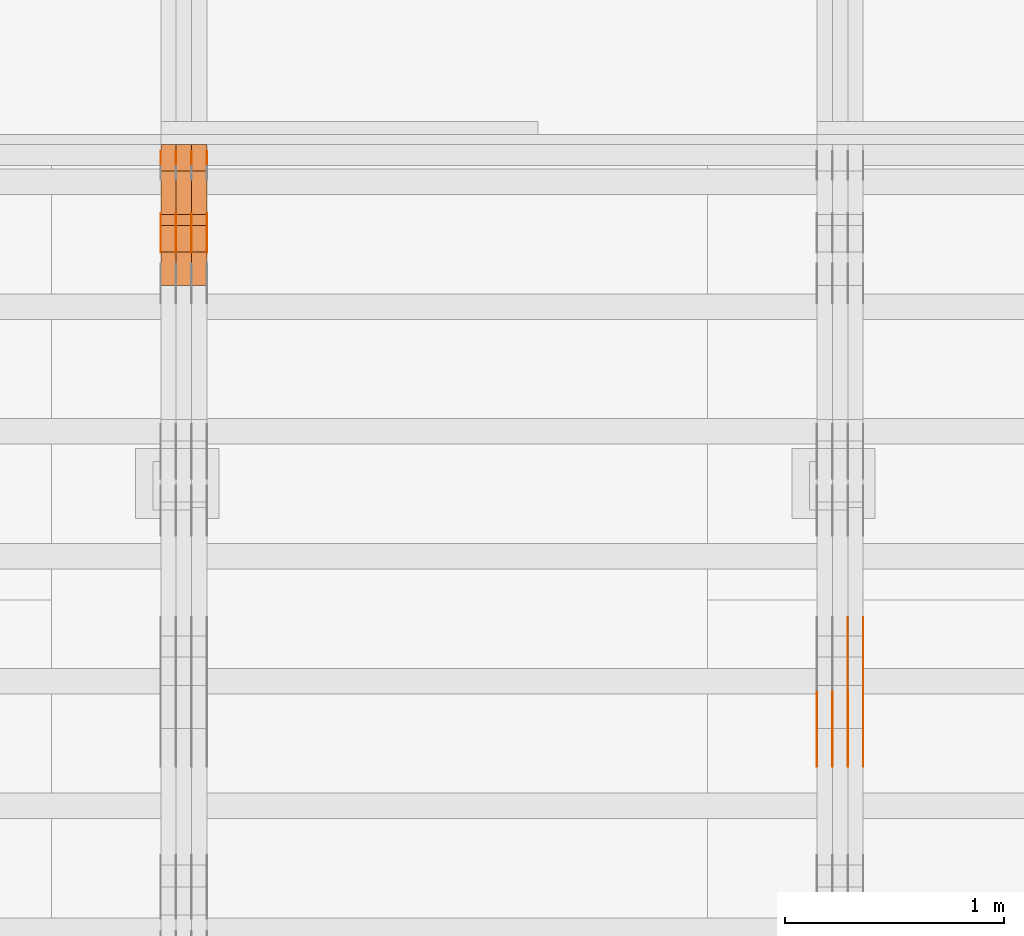
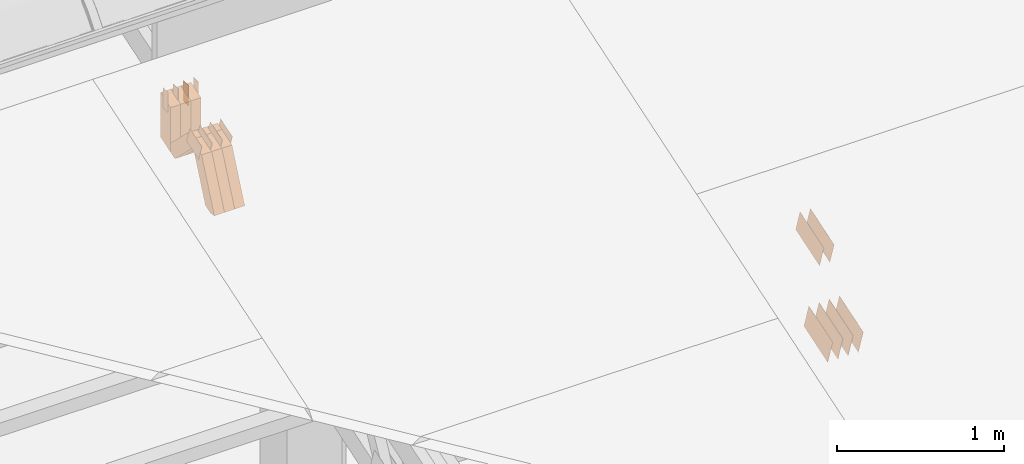
# One storey, part 279 of 385: 29 proxies.
"""IFC2X3 building model written with IfcOpenShell, lengths in millimetres."""

import ifcopenshell
import ifcopenshell.guid

model = None  # the IFC model being written
_history = None  # IfcOwnerHistory: only IFC2X3 demands one
_inside = {}  # id of a spatial element -> (the spatial element, [elements in it])
_under = {}  # id of a project, library or spatial element -> (it, [spatial elements below it])
_declared = {}  # id of a project -> (the project, [libraries it declares])
_typed = {}  # id of a type object -> (the type object, [elements of that type])
_made_of = {}  # id of a material, layer set ... -> (it, [elements and type objects made of it])


def new_model(schema):
    """Start an empty IFC model of exactly this schema.

    Asked for "IFC4X3", IfcOpenShell would pick the latest addendum, in which some entities
    have other attributes; the version numbers below select the first issue.
    IFC2X3 requires an IfcOwnerHistory on every rooted entity: one is made here for all.
    """
    global model, _history
    if schema == "IFC4X3":
        model = ifcopenshell.file(schema_version=(4, 3, 0, 0))
    else:
        model = ifcopenshell.file(schema=schema)
    _inside.clear()
    _under.clear()
    _declared.clear()
    _typed.clear()
    _made_of.clear()
    _history = None
    if model.schema == "IFC2X3":
        org = make("IfcOrganization", Name="unknown")
        user = make(
            "IfcPersonAndOrganization",
            ThePerson=make("IfcPerson", FamilyName="unknown"),
            TheOrganization=org,
        )
        app = make(
            "IfcApplication",
            ApplicationDeveloper=org,
            Version="unknown",
            ApplicationFullName="unknown",
            ApplicationIdentifier="unknown",
        )
        _history = make(
            "IfcOwnerHistory",
            OwningUser=user,
            OwningApplication=app,
            ChangeAction="ADDED",
            CreationDate=0,
        )
    return model


def make(cls, **values):
    """One entity of the class cls with the attributes given. An attribute that is None is left unset."""
    return model.create_entity(
        cls, **{name: value for name, value in values.items() if value is not None}
    )


def entity(cls, *values):
    """Any entity or typed value of the class cls, its attributes in the order of the schema. None: left unset."""
    e = model.create_entity(cls)
    for i, value in enumerate(values):
        if value is not None:
            e[i] = value
    return e


def rooted(cls, **values):
    """An entity with a GlobalId (a new one), such as an element, a storey or a relation."""
    return make(cls, GlobalId=ifcopenshell.guid.new(), OwnerHistory=_history, **values)


def si_unit(unit_type, name, prefix=None):
    """IfcSIUnit, for example si_unit("LENGTHUNIT", "METRE", prefix="MILLI")."""
    return make("IfcSIUnit", UnitType=unit_type, Prefix=prefix, Name=name)


def converted_unit(unit_type, name, factor, base, dimensions=None, offset=None):
    """IfcConversionBasedUnit, such as the inch: factor (a typed value) times the base unit."""
    return make(
        "IfcConversionBasedUnit"
        if offset is None
        else "IfcConversionBasedUnitWithOffset",
        ConversionOffset=offset,
        Dimensions=None
        if dimensions is None
        else entity("IfcDimensionalExponents", *dimensions),
        UnitType=unit_type,
        Name=name,
        ConversionFactor=make(
            "IfcMeasureWithUnit", ValueComponent=factor, UnitComponent=base
        ),
    )


def derived_unit(unit_type, elements):
    """IfcDerivedUnit: a product of units, each with its exponent."""
    return make(
        "IfcDerivedUnit",
        Elements=[
            make("IfcDerivedUnitElement", Unit=unit, Exponent=power)
            for unit, power in elements
        ],
        UnitType=unit_type,
    )


def assignment(units):
    """IfcUnitAssignment: the units of a project."""
    return None if units is None else make("IfcUnitAssignment", Units=units)


def point(xyz):
    """IfcCartesianPoint."""
    return None if xyz is None else make("IfcCartesianPoint", Coordinates=xyz)


def direction(xyz):
    """IfcDirection."""
    return None if xyz is None else make("IfcDirection", DirectionRatios=xyz)


def frame(location, z_axis=None, x_axis=None):
    """IfcAxis2Placement3D, a coordinate frame: its origin and axes. An axis left out is left unset."""
    return make(
        "IfcAxis2Placement3D",
        Location=point(location),
        Axis=direction(z_axis),
        RefDirection=direction(x_axis),
    )


def frame_2d(location, x_axis=None):
    """IfcAxis2Placement2D, a coordinate frame in the plane: its origin and x axis."""
    return make(
        "IfcAxis2Placement2D", Location=point(location), RefDirection=direction(x_axis)
    )


def origin():
    """The frame at (0, 0, 0) with its axes left unset."""
    return frame((0.0, 0.0, 0.0))


def origin_2d_with_axis():
    """The frame at (0, 0) in the plane with the x axis (1, 0) written out."""
    return frame_2d((0.0, 0.0), x_axis=(1.0, 0.0))


def place(relative_to, where):
    """IfcLocalPlacement: puts the frame where relative to a parent placement (None: the world)."""
    return make(
        "IfcLocalPlacement", PlacementRelTo=relative_to, RelativePlacement=where
    )


def context(
    kind, dimensions, precision=None, world=None, true_north=None, identifier=None
):
    """IfcGeometricRepresentationContext, for example the 3D "Model" context."""
    return make(
        "IfcGeometricRepresentationContext",
        ContextIdentifier=identifier,
        ContextType=kind,
        CoordinateSpaceDimension=dimensions,
        Precision=precision,
        WorldCoordinateSystem=world,
        TrueNorth=true_north,
    )


def subcontext(parent, identifier, kind, view, scale=None):
    """IfcGeometricRepresentationSubContext, for example "Body" below "Model"."""
    return make(
        "IfcGeometricRepresentationSubContext",
        ContextIdentifier=identifier,
        ContextType=kind,
        ParentContext=parent,
        TargetScale=scale,
        TargetView=view,
    )


def project(units=None, contexts=None):
    """IfcProject with its units and contexts."""
    return rooted(
        "IfcProject",
        Name="project",
        RepresentationContexts=contexts,
        UnitsInContext=assignment(units),
    )


def spatial(cls, under=None, at=None, **own):
    """A site, building, storey or space (cls), placed at a placement, below another one or the project."""
    s = rooted(cls, ObjectPlacement=at, **own)
    if under is not None:
        _under.setdefault(under.id(), (under, []))[1].append(s)
    return s


def polyline(points):
    """IfcPolyline through the points."""
    return make("IfcPolyline", Points=[point(p) for p in points])


def profile(cls, at=None, kind="AREA", **sizes):
    """A parametric profile (cls). Its sizes go by their IFC names, for example OverallWidth=200.0."""
    return make(cls, ProfileType=kind, Position=at, **sizes)


def rectangle(**sizes):
    """IfcRectangleProfileDef."""
    return profile("IfcRectangleProfileDef", **sizes)


def outline(outer, holes=None, kind="AREA"):
    """IfcArbitraryClosedProfileDef: a profile drawn as a closed curve; with holes, ...WithVoids."""
    if holes is None:
        return make("IfcArbitraryClosedProfileDef", ProfileType=kind, OuterCurve=outer)
    return make(
        "IfcArbitraryProfileDefWithVoids",
        ProfileType=kind,
        OuterCurve=outer,
        InnerCurves=holes,
    )


def extrude(swept, where, along, depth):
    """IfcExtrudedAreaSolid: the profile swept, set in the frame where, extruded along a direction by depth."""
    return make(
        "IfcExtrudedAreaSolid",
        SweptArea=swept,
        Position=where,
        ExtrudedDirection=direction(along),
        Depth=depth,
    )


def shape(context_of_items, identifier, shape_type, items):
    """IfcShapeRepresentation: the items that make up one representation, for example the "Body"."""
    return make(
        "IfcShapeRepresentation",
        ContextOfItems=context_of_items,
        RepresentationIdentifier=identifier,
        RepresentationType=shape_type,
        Items=items,
    )


def source(mapping_origin, context_of_items, identifier, shape_type, items):
    """IfcRepresentationMap: a shape defined once, which mapped items show again and again."""
    return make(
        "IfcRepresentationMap",
        MappingOrigin=mapping_origin,
        MappedRepresentation=shape(context_of_items, identifier, shape_type, items),
    )


def transform(
    local_origin,
    x_axis=None,
    y_axis=None,
    z_axis=None,
    scale=None,
    scale2=None,
    scale3=None,
    uniform=True,
):
    """IfcCartesianTransformationOperator3D, or its non-uniform kind. x_axis, y_axis, z_axis: its Axis1, 2, 3."""
    if uniform:
        return make(
            "IfcCartesianTransformationOperator3D",
            Axis1=direction(x_axis),
            Axis2=direction(y_axis),
            LocalOrigin=point(local_origin),
            Scale=scale,
            Axis3=direction(z_axis),
        )
    return make(
        "IfcCartesianTransformationOperator3DnonUniform",
        Axis1=direction(x_axis),
        Axis2=direction(y_axis),
        LocalOrigin=point(local_origin),
        Scale=scale,
        Axis3=direction(z_axis),
        Scale2=scale2,
        Scale3=scale3,
    )


def mapped(mapping_source, mapping_target):
    """IfcMappedItem: shows the shape of a source again, moved by a transform."""
    return make(
        "IfcMappedItem", MappingSource=mapping_source, MappingTarget=mapping_target
    )


def material(Name=None, Category=None):
    """IfcMaterial."""
    return make("IfcMaterial", Name=Name, Category=Category)


def made_of(thing, what):
    """Note that an element or type object is made of a material, layer set ...; save() writes the relation."""
    if what is not None:
        _made_of.setdefault(what.id(), (what, []))[1].append(thing)
    return thing


def type_object(cls, material=None, **own):
    """A type object (cls), such as IfcWallType, which elements share."""
    return made_of(rooted(cls, **own), material)


def type_shapes(of_type, sources):
    """Give a type object the sources (RepresentationMaps) that its elements show as mapped items."""
    of_type.RepresentationMaps = sources


def element(
    cls,
    number,
    at=None,
    inside=None,
    cuts=None,
    type_object=None,
    material=None,
    context=None,
    identifier="Body",
    shape_type=None,
    held_by="IfcProductDefinitionShape",
    body=None,
    shapes=None,
    **own,
):
    """One element of the class cls, such as IfcWall. Its Tag is "e" and its number.

    at: its placement. inside: the storey or other place that contains it. cuts: it is an
    opening in that element (IfcRelVoidsElement). A single representation is given by context,
    identifier, shape_type and body (its items); several are given by shapes. held_by: the class
    of the entity that holds the representations. save() writes the other relations.
    """
    e = rooted(cls, Tag="e%d" % number, ObjectPlacement=at, **own)
    if body is not None:
        shapes = [shape(context, identifier, shape_type, body)]
    if shapes is not None:
        e.Representation = make(held_by, Representations=shapes)
    if inside is not None:
        _inside.setdefault(inside.id(), (inside, []))[1].append(e)
    if cuts is not None:
        rooted(
            "IfcRelVoidsElement", RelatingBuildingElement=cuts, RelatedOpeningElement=e
        )
    if type_object is not None:
        _typed.setdefault(type_object.id(), (type_object, []))[1].append(e)
    return made_of(e, material)


def aggregate(whole, parts):
    """IfcRelAggregates: a whole, such as a stair, and the parts it consists of."""
    return rooted("IfcRelAggregates", RelatingObject=whole, RelatedObjects=parts)


def save(model, path):
    """Write the relations noted so far, then the file.

    IfcRelAggregates (storeys below a building ...), IfcRelContainedInSpatialStructure (elements
    in a storey), IfcRelDefinesByType, IfcRelAssociatesMaterial and IfcRelDeclares: one each for
    every whole, place, type object, material and project.
    """
    for whole, parts in _under.values():
        aggregate(whole, parts)
    for where, things in _inside.values():
        rooted(
            "IfcRelContainedInSpatialStructure",
            RelatedElements=things,
            RelatingStructure=where,
        )
    for kind, things in _typed.values():
        rooted("IfcRelDefinesByType", RelatedObjects=things, RelatingType=kind)
    for what, things in _made_of.values():
        rooted("IfcRelAssociatesMaterial", RelatedObjects=things, RelatingMaterial=what)
    for by, libraries in _declared.values():
        rooted("IfcRelDeclares", RelatingContext=by, RelatedDefinitions=libraries)
    model.write(path)


model = new_model("IFC2X3")

# Units and contexts
model_context = context("Model", 3, precision=0.01, world=origin(), true_north=direction((6.12303176911189e-17, 1.0)))
body_context = subcontext(model_context, "Body", "Model", "MODEL_VIEW")
ifc_project = project(units=[si_unit("LENGTHUNIT", "METRE", prefix="MILLI"), si_unit("AREAUNIT", "SQUARE_METRE"), si_unit("VOLUMEUNIT", "CUBIC_METRE"), converted_unit("PLANEANGLEUNIT", "DEGREE", entity("IfcRatioMeasure", 0.0174532925199433), si_unit("PLANEANGLEUNIT", "RADIAN"), dimensions=[0, 0, 0, 0, 0, 0, 0]), si_unit("MASSUNIT", "GRAM", prefix="KILO"), derived_unit("MASSDENSITYUNIT", [(si_unit("MASSUNIT", "GRAM", prefix="KILO"), 1), (si_unit("LENGTHUNIT", "METRE"), -3)]), si_unit("TIMEUNIT", "SECOND"), si_unit("FREQUENCYUNIT", "HERTZ"), si_unit("THERMODYNAMICTEMPERATUREUNIT", "DEGREE_CELSIUS"), derived_unit("THERMALTRANSMITTANCEUNIT", [(si_unit("MASSUNIT", "GRAM", prefix="KILO"), 1), (si_unit("THERMODYNAMICTEMPERATUREUNIT", "KELVIN"), -1), (si_unit("TIMEUNIT", "SECOND"), -3)]), derived_unit("VOLUMETRICFLOWRATEUNIT", [(si_unit("LENGTHUNIT", "METRE"), 3), (si_unit("TIMEUNIT", "SECOND"), -1)]), si_unit("ELECTRICCURRENTUNIT", "AMPERE"), si_unit("ELECTRICVOLTAGEUNIT", "VOLT"), si_unit("POWERUNIT", "WATT"), si_unit("FORCEUNIT", "NEWTON", prefix="KILO"), si_unit("ILLUMINANCEUNIT", "LUX"), si_unit("LUMINOUSFLUXUNIT", "LUMEN"), si_unit("LUMINOUSINTENSITYUNIT", "CANDELA"), derived_unit("USERDEFINED", [(si_unit("MASSUNIT", "GRAM", prefix="KILO"), -1), (si_unit("LENGTHUNIT", "METRE"), -2), (si_unit("TIMEUNIT", "SECOND"), 3), (si_unit("LUMINOUSFLUXUNIT", "LUMEN"), 1)]), derived_unit("LINEARVELOCITYUNIT", [(si_unit("LENGTHUNIT", "METRE"), 1), (si_unit("TIMEUNIT", "SECOND"), -1)]), si_unit("PRESSUREUNIT", "PASCAL"), derived_unit("USERDEFINED", [(si_unit("LENGTHUNIT", "METRE"), -2), (si_unit("MASSUNIT", "GRAM", prefix="KILO"), 1), (si_unit("TIMEUNIT", "SECOND"), -2)])], contexts=[model_context])

# Site, building, storey
site_placement = place(None, origin())
site = spatial("IfcSite", under=ifc_project, at=site_placement, CompositionType="ELEMENT")
building_placement = place(site_placement, origin())
building = spatial("IfcBuilding", under=site, at=building_placement, CompositionType="ELEMENT")
storey_placement = place(building_placement, origin())
storey = spatial("IfcBuildingStorey", under=building, at=storey_placement, Name="Default", CompositionType="ELEMENT", Elevation=0.0)

# Proxies
ifc_material_1 = material(Name="IfcSurfaceStyle #449480")
building_element_proxy_type_1 = type_object("IfcBuildingElementProxyType", PredefinedType="NOTDEFINED", material=ifc_material_1)
shared_shape_1 = source(origin(), body_context, "Body", "SweptSolid", [
    extrude(outline(polyline([(-149.99966632326, -95.9999759039407), (149.999881095801, -95.9999759039407), (150.000557367591, 95.9999759039407), (-150.000772140132, 95.9999759039406), (-149.99966632326, -95.9999759039407)])), frame((150.000557367591, 96.0004291135906, 0.0), z_axis=(0.0, 0.0, 1.0), x_axis=(-1.0, 0.0, 0.0)), (0.0, 0.0, 1.0), 1.29999999999999),
])
type_shapes(building_element_proxy_type_1, [shared_shape_1])
proxy_1_placement = place(building_placement, frame((36386.3, 10934.7734375, 2766.8759765625), z_axis=(-1.0, 0.0, 0.0), x_axis=(0.0, 0.951056516295124, 0.309016994375039)))
element("IfcBuildingElementProxy", 1, at=proxy_1_placement, inside=storey, type_object=building_element_proxy_type_1, material=ifc_material_1, context=body_context, shape_type="MappedRepresentation", body=[
    mapped(shared_shape_1, transform((0.0, 0.0, 0.0), scale=1.0)),
])
ifc_material_2 = material(Name="IfcSurfaceStyle #449423")
building_element_proxy_type_2 = type_object("IfcBuildingElementProxyType", PredefinedType="NOTDEFINED", material=ifc_material_2)
shared_shape_2 = source(origin(), body_context, "Body", "SweptSolid", [
    extrude(outline(polyline([(-149.99966632326, -95.9999759039407), (149.999881095801, -95.9999759039407), (150.000557367591, 95.9999759039407), (-150.000772140132, 95.9999759039406), (-149.99966632326, -95.9999759039407)])), frame((150.000557367591, 96.0004291135906, 0.0), z_axis=(0.0, 0.0, 1.0), x_axis=(-1.0, 0.0, 0.0)), (0.0, 0.0, 1.0), 1.29999999999999),
])
type_shapes(building_element_proxy_type_2, [shared_shape_2])
proxy_2_placement = place(building_placement, frame((36315.0, 10934.7734375, 2766.8759765625), z_axis=(-1.0, 0.0, 0.0), x_axis=(0.0, 0.951056516295124, 0.309016994375039)))
element("IfcBuildingElementProxy", 2, at=proxy_2_placement, inside=storey, type_object=building_element_proxy_type_2, material=ifc_material_2, context=body_context, shape_type="MappedRepresentation", body=[
    mapped(shared_shape_2, transform((0.0, 0.0, 0.0), scale=1.0)),
])
ifc_material_3 = material(Name="IfcSurfaceStyle #449366")
building_element_proxy_type_3 = type_object("IfcBuildingElementProxyType", PredefinedType="NOTDEFINED", material=ifc_material_3)
shared_shape_3 = source(origin(), body_context, "Body", "SweptSolid", [
    extrude(outline(polyline([(-149.99966632326, -95.9999759039407), (149.999881095801, -95.9999759039407), (150.000557367591, 95.9999759039407), (-150.000772140132, 95.9999759039406), (-149.99966632326, -95.9999759039407)])), frame((150.000557367591, 96.0004291135906, 0.0), z_axis=(0.0, 0.0, 1.0), x_axis=(-1.0, 0.0, 0.0)), (0.0, 0.0, 1.0), 1.29999999999999),
])
type_shapes(building_element_proxy_type_3, [shared_shape_3])
proxy_3_placement = place(building_placement, frame((36316.3, 10934.7734375, 2766.8759765625), z_axis=(-1.0, 0.0, 0.0), x_axis=(0.0, 0.951056516295124, 0.309016994375039)))
element("IfcBuildingElementProxy", 3, at=proxy_3_placement, inside=storey, type_object=building_element_proxy_type_3, material=ifc_material_3, context=body_context, shape_type="MappedRepresentation", body=[
    mapped(shared_shape_3, transform((0.0, 0.0, 0.0), scale=1.0)),
])
ifc_material_4 = material(Name="IfcSurfaceStyle #449309")
building_element_proxy_type_4 = type_object("IfcBuildingElementProxyType", PredefinedType="NOTDEFINED", material=ifc_material_4)
shared_shape_4 = source(origin(), body_context, "Body", "SweptSolid", [
    extrude(outline(polyline([(-149.99966632326, -95.9999759039407), (149.999881095801, -95.9999759039407), (150.000557367591, 95.9999759039407), (-150.000772140132, 95.9999759039406), (-149.99966632326, -95.9999759039407)])), frame((150.000557367591, 96.0004291135906, 0.0), z_axis=(0.0, 0.0, 1.0), x_axis=(-1.0, 0.0, 0.0)), (0.0, 0.0, 1.0), 1.29999999999998),
])
type_shapes(building_element_proxy_type_4, [shared_shape_4])
proxy_4_placement = place(building_placement, frame((36245.0, 10934.7734375, 2766.8759765625), z_axis=(-1.0, 0.0, 0.0), x_axis=(0.0, 0.951056516295124, 0.309016994375039)))
element("IfcBuildingElementProxy", 4, at=proxy_4_placement, inside=storey, type_object=building_element_proxy_type_4, material=ifc_material_4, context=body_context, shape_type="MappedRepresentation", body=[
    mapped(shared_shape_4, transform((0.0, 0.0, 0.0), scale=1.0)),
])
ifc_material_5 = material(Name="IfcSurfaceStyle #449252")
building_element_proxy_type_5 = type_object("IfcBuildingElementProxyType", PredefinedType="NOTDEFINED", material=ifc_material_5)
shared_shape_5 = source(origin(), body_context, "Body", "SweptSolid", [
    extrude(outline(polyline([(-149.99966632326, -95.9999759039407), (149.999881095801, -95.9999759039407), (150.000557367591, 95.9999759039407), (-150.000772140132, 95.9999759039406), (-149.99966632326, -95.9999759039407)])), frame((150.000557367591, 96.0004291135906, 0.0), z_axis=(0.0, 0.0, 1.0), x_axis=(-1.0, 0.0, 0.0)), (0.0, 0.0, 1.0), 1.29999999999998),
])
type_shapes(building_element_proxy_type_5, [shared_shape_5])
proxy_5_placement = place(building_placement, frame((36246.3, 10934.7734375, 2766.8759765625), z_axis=(-1.0, 0.0, 0.0), x_axis=(0.0, 0.951056516295124, 0.309016994375039)))
element("IfcBuildingElementProxy", 5, at=proxy_5_placement, inside=storey, type_object=building_element_proxy_type_5, material=ifc_material_5, context=body_context, shape_type="MappedRepresentation", body=[
    mapped(shared_shape_5, transform((0.0, 0.0, 0.0), scale=1.0)),
])
ifc_material_6 = material(Name="IfcSurfaceStyle #449195")
building_element_proxy_type_6 = type_object("IfcBuildingElementProxyType", PredefinedType="NOTDEFINED", material=ifc_material_6)
shared_shape_6 = source(origin(), body_context, "Body", "SweptSolid", [
    extrude(outline(polyline([(-149.99966632326, -95.9999759039407), (149.999881095801, -95.9999759039407), (150.000557367591, 95.9999759039407), (-150.000772140132, 95.9999759039406), (-149.99966632326, -95.9999759039407)])), frame((150.000557367591, 96.0004291135906, 0.0), z_axis=(0.0, 0.0, 1.0), x_axis=(-1.0, 0.0, 0.0)), (0.0, 0.0, 1.0), 1.29999999999998),
])
type_shapes(building_element_proxy_type_6, [shared_shape_6])
proxy_6_placement = place(building_placement, frame((36175.0, 10934.7734375, 2766.8759765625), z_axis=(-1.0, 0.0, 0.0), x_axis=(0.0, 0.951056516295124, 0.309016994375039)))
element("IfcBuildingElementProxy", 6, at=proxy_6_placement, inside=storey, type_object=building_element_proxy_type_6, material=ifc_material_6, context=body_context, shape_type="MappedRepresentation", body=[
    mapped(shared_shape_6, transform((0.0, 0.0, 0.0), scale=1.0)),
])
ifc_material_7 = material(Name="IfcSurfaceStyle #439904")
building_element_proxy_type_7 = type_object("IfcBuildingElementProxyType", PredefinedType="NOTDEFINED", material=ifc_material_7)
shared_shape_7 = source(origin(), body_context, "Body", "SweptSolid", [
    extrude(outline(polyline([(-150.000273478628, -84.0002987844282), (149.999198496832, -84.0002987844282), (150.000273478627, 84.0002987844282), (-149.999198496831, 84.0002987844282), (-150.000273478628, -84.0002987844282)])), frame((150.000273478627, 84.0002987844282, 0.0), z_axis=(0.0, 0.0, 1.0), x_axis=(-1.0, 0.0, 0.0)), (0.0, 0.0, 1.0), 1.29999999999999),
])
type_shapes(building_element_proxy_type_7, [shared_shape_7])
proxy_7_placement = place(building_placement, frame((36386.3, 11283.0116722926, 3194.09682266857), z_axis=(-1.0, 0.0, 0.0), x_axis=(0.0, 0.951056516295154, 0.309016994374948)))
element("IfcBuildingElementProxy", 7, at=proxy_7_placement, inside=storey, type_object=building_element_proxy_type_7, material=ifc_material_7, context=body_context, shape_type="MappedRepresentation", body=[
    mapped(shared_shape_7, transform((0.0, 0.0, 0.0), scale=1.0)),
])
ifc_material_8 = material(Name="IfcSurfaceStyle #439847")
building_element_proxy_type_8 = type_object("IfcBuildingElementProxyType", PredefinedType="NOTDEFINED", material=ifc_material_8)
shared_shape_8 = source(origin(), body_context, "Body", "SweptSolid", [
    extrude(outline(polyline([(-150.000273478628, -84.0002987844282), (149.999198496832, -84.0002987844282), (150.000273478627, 84.0002987844282), (-149.999198496831, 84.0002987844282), (-150.000273478628, -84.0002987844282)])), frame((150.000273478627, 84.0002987844282, 0.0), z_axis=(0.0, 0.0, 1.0), x_axis=(-1.0, 0.0, 0.0)), (0.0, 0.0, 1.0), 1.29999999999999),
])
type_shapes(building_element_proxy_type_8, [shared_shape_8])
proxy_8_placement = place(building_placement, frame((36315.0, 11283.0116722926, 3194.09682266857), z_axis=(-1.0, 0.0, 0.0), x_axis=(0.0, 0.951056516295154, 0.309016994374948)))
element("IfcBuildingElementProxy", 8, at=proxy_8_placement, inside=storey, type_object=building_element_proxy_type_8, material=ifc_material_8, context=body_context, shape_type="MappedRepresentation", body=[
    mapped(shared_shape_8, transform((0.0, 0.0, 0.0), scale=1.0)),
])
ifc_material_9 = material(Name="IfcSurfaceStyle #407524")
building_element_proxy_type_9 = type_object("IfcBuildingElementProxyType", PredefinedType="NOTDEFINED", material=ifc_material_9)
shared_shape_9 = source(origin(), body_context, "Body", "SweptSolid", [
    extrude(outline(polyline([(-74.999875428623, -60.0000016373506), (74.9998605591059, -60.0000016373506), (74.9998754286239, 60.0000016373506), (-74.9998605591068, 60.0000016373506), (-74.999875428623, -60.0000016373506)])), frame((75.0002691827262, 60.0000190504561, 0.0), z_axis=(0.0, 0.0, 1.0), x_axis=(-1.0, 0.0, 0.0)), (0.0, 0.0, 1.0), 1.3),
])
type_shapes(building_element_proxy_type_9, [shared_shape_9])
proxy_9_placement = place(building_placement, frame((33386.3, 13285.0865109705, 3819.37496637467), z_axis=(-1.0, 0.0, 0.0), x_axis=(0.0, 0.951056516295154, 0.309016994374948)))
element("IfcBuildingElementProxy", 9, at=proxy_9_placement, inside=storey, type_object=building_element_proxy_type_9, material=ifc_material_9, context=body_context, shape_type="MappedRepresentation", body=[
    mapped(shared_shape_9, transform((0.0, 0.0, 0.0), scale=1.0)),
])
ifc_material_10 = material(Name="IfcSurfaceStyle #407467")
building_element_proxy_type_10 = type_object("IfcBuildingElementProxyType", PredefinedType="NOTDEFINED", material=ifc_material_10)
shared_shape_10 = source(origin(), body_context, "Body", "SweptSolid", [
    extrude(outline(polyline([(-74.999875428623, -60.0000016373506), (74.9998605591059, -60.0000016373506), (74.9998754286239, 60.0000016373506), (-74.9998605591068, 60.0000016373506), (-74.999875428623, -60.0000016373506)])), frame((75.0002691827262, 60.0000190504561, 0.0), z_axis=(0.0, 0.0, 1.0), x_axis=(-1.0, 0.0, 0.0)), (0.0, 0.0, 1.0), 1.3),
])
type_shapes(building_element_proxy_type_10, [shared_shape_10])
proxy_10_placement = place(building_placement, frame((33315.0, 13285.0865109705, 3819.37496637467), z_axis=(-1.0, 0.0, 0.0), x_axis=(0.0, 0.951056516295154, 0.309016994374948)))
element("IfcBuildingElementProxy", 10, at=proxy_10_placement, inside=storey, type_object=building_element_proxy_type_10, material=ifc_material_10, context=body_context, shape_type="MappedRepresentation", body=[
    mapped(shared_shape_10, transform((0.0, 0.0, 0.0), scale=1.0)),
])
ifc_material_11 = material(Name="IfcSurfaceStyle #407410")
building_element_proxy_type_11 = type_object("IfcBuildingElementProxyType", PredefinedType="NOTDEFINED", material=ifc_material_11)
shared_shape_11 = source(origin(), body_context, "Body", "SweptSolid", [
    extrude(outline(polyline([(-74.999875428623, -60.0000016373506), (74.9998605591059, -60.0000016373506), (74.9998754286239, 60.0000016373506), (-74.9998605591068, 60.0000016373506), (-74.999875428623, -60.0000016373506)])), frame((75.0002691827262, 60.0000190504561, 0.0), z_axis=(0.0, 0.0, 1.0), x_axis=(-1.0, 0.0, 0.0)), (0.0, 0.0, 1.0), 1.3),
])
type_shapes(building_element_proxy_type_11, [shared_shape_11])
proxy_11_placement = place(building_placement, frame((33316.3, 13285.0865109705, 3819.37496637467), z_axis=(-1.0, 0.0, 0.0), x_axis=(0.0, 0.951056516295154, 0.309016994374948)))
element("IfcBuildingElementProxy", 11, at=proxy_11_placement, inside=storey, type_object=building_element_proxy_type_11, material=ifc_material_11, context=body_context, shape_type="MappedRepresentation", body=[
    mapped(shared_shape_11, transform((0.0, 0.0, 0.0), scale=1.0)),
])
ifc_material_12 = material(Name="IfcSurfaceStyle #407353")
building_element_proxy_type_12 = type_object("IfcBuildingElementProxyType", PredefinedType="NOTDEFINED", material=ifc_material_12)
shared_shape_12 = source(origin(), body_context, "Body", "SweptSolid", [
    extrude(outline(polyline([(-74.999875428623, -60.0000016373506), (74.9998605591059, -60.0000016373506), (74.9998754286239, 60.0000016373506), (-74.9998605591068, 60.0000016373506), (-74.999875428623, -60.0000016373506)])), frame((75.0002691827262, 60.0000190504561, 0.0), z_axis=(0.0, 0.0, 1.0), x_axis=(-1.0, 0.0, 0.0)), (0.0, 0.0, 1.0), 1.29999999999999),
])
type_shapes(building_element_proxy_type_12, [shared_shape_12])
proxy_12_placement = place(building_placement, frame((33245.0, 13285.0865109705, 3819.37496637467), z_axis=(-1.0, 0.0, 0.0), x_axis=(0.0, 0.951056516295154, 0.309016994374948)))
element("IfcBuildingElementProxy", 12, at=proxy_12_placement, inside=storey, type_object=building_element_proxy_type_12, material=ifc_material_12, context=body_context, shape_type="MappedRepresentation", body=[
    mapped(shared_shape_12, transform((0.0, 0.0, 0.0), scale=1.0)),
])
ifc_material_13 = material(Name="IfcSurfaceStyle #407296")
building_element_proxy_type_13 = type_object("IfcBuildingElementProxyType", PredefinedType="NOTDEFINED", material=ifc_material_13)
shared_shape_13 = source(origin(), body_context, "Body", "SweptSolid", [
    extrude(outline(polyline([(-74.999875428623, -60.0000016373506), (74.9998605591059, -60.0000016373506), (74.9998754286239, 60.0000016373506), (-74.9998605591068, 60.0000016373506), (-74.999875428623, -60.0000016373506)])), frame((75.0002691827262, 60.0000190504561, 0.0), z_axis=(0.0, 0.0, 1.0), x_axis=(-1.0, 0.0, 0.0)), (0.0, 0.0, 1.0), 1.29999999999999),
])
type_shapes(building_element_proxy_type_13, [shared_shape_13])
proxy_13_placement = place(building_placement, frame((33246.3, 13285.0865109705, 3819.37496637467), z_axis=(-1.0, 0.0, 0.0), x_axis=(0.0, 0.951056516295154, 0.309016994374948)))
element("IfcBuildingElementProxy", 13, at=proxy_13_placement, inside=storey, type_object=building_element_proxy_type_13, material=ifc_material_13, context=body_context, shape_type="MappedRepresentation", body=[
    mapped(shared_shape_13, transform((0.0, 0.0, 0.0), scale=1.0)),
])
ifc_material_14 = material(Name="IfcSurfaceStyle #407239")
building_element_proxy_type_14 = type_object("IfcBuildingElementProxyType", PredefinedType="NOTDEFINED", material=ifc_material_14)
shared_shape_14 = source(origin(), body_context, "Body", "SweptSolid", [
    extrude(outline(polyline([(-74.999875428623, -60.0000016373506), (74.9998605591059, -60.0000016373506), (74.9998754286239, 60.0000016373506), (-74.9998605591068, 60.0000016373506), (-74.999875428623, -60.0000016373506)])), frame((75.0002691827262, 60.0000190504561, 0.0), z_axis=(0.0, 0.0, 1.0), x_axis=(-1.0, 0.0, 0.0)), (0.0, 0.0, 1.0), 1.29999999999999),
])
type_shapes(building_element_proxy_type_14, [shared_shape_14])
proxy_14_placement = place(building_placement, frame((33175.0, 13285.0865109705, 3819.37496637467), z_axis=(-1.0, 0.0, 0.0), x_axis=(0.0, 0.951056516295154, 0.309016994374948)))
element("IfcBuildingElementProxy", 14, at=proxy_14_placement, inside=storey, type_object=building_element_proxy_type_14, material=ifc_material_14, context=body_context, shape_type="MappedRepresentation", body=[
    mapped(shared_shape_14, transform((0.0, 0.0, 0.0), scale=1.0)),
])
ifc_material_15 = material(Name="IfcSurfaceStyle #406840")
building_element_proxy_type_15 = type_object("IfcBuildingElementProxyType", PredefinedType="NOTDEFINED", material=ifc_material_15)
shared_shape_15 = source(origin(), body_context, "Body", "SweptSolid", [
    extrude(rectangle(XDim=150.0, YDim=60.0, at=origin_2d_with_axis()), frame((75.0000705696166, 30.0, 0.0), z_axis=(0.0, 0.0, 1.0), x_axis=(-1.0, 0.0, 0.0)), (0.0, 0.0, 1.0), 1.3),
])
type_shapes(building_element_proxy_type_15, [shared_shape_15])
proxy_15_placement = place(building_placement, frame((33386.3, 13750.0, 3972.59919166337), z_axis=(-1.0, 0.0, 0.0), x_axis=(0.0, 0.0, -1.0)))
element("IfcBuildingElementProxy", 15, at=proxy_15_placement, inside=storey, type_object=building_element_proxy_type_15, material=ifc_material_15, context=body_context, shape_type="MappedRepresentation", body=[
    mapped(shared_shape_15, transform((0.0, 0.0, 0.0), scale=1.0)),
])
ifc_material_16 = material(Name="IfcSurfaceStyle #406783")
building_element_proxy_type_16 = type_object("IfcBuildingElementProxyType", PredefinedType="NOTDEFINED", material=ifc_material_16)
shared_shape_16 = source(origin(), body_context, "Body", "SweptSolid", [
    extrude(rectangle(XDim=150.0, YDim=60.0, at=origin_2d_with_axis()), frame((75.0000705696166, 30.0, 0.0), z_axis=(0.0, 0.0, 1.0), x_axis=(-1.0, 0.0, 0.0)), (0.0, 0.0, 1.0), 1.3),
])
type_shapes(building_element_proxy_type_16, [shared_shape_16])
proxy_16_placement = place(building_placement, frame((33315.0, 13750.0, 3972.59919166337), z_axis=(-1.0, 0.0, 0.0), x_axis=(0.0, 0.0, -1.0)))
element("IfcBuildingElementProxy", 16, at=proxy_16_placement, inside=storey, type_object=building_element_proxy_type_16, material=ifc_material_16, context=body_context, shape_type="MappedRepresentation", body=[
    mapped(shared_shape_16, transform((0.0, 0.0, 0.0), scale=1.0)),
])
ifc_material_17 = material(Name="IfcSurfaceStyle #406726")
building_element_proxy_type_17 = type_object("IfcBuildingElementProxyType", PredefinedType="NOTDEFINED", material=ifc_material_17)
shared_shape_17 = source(origin(), body_context, "Body", "SweptSolid", [
    extrude(rectangle(XDim=150.0, YDim=60.0, at=origin_2d_with_axis()), frame((75.0000705696166, 30.0, 0.0), z_axis=(0.0, 0.0, 1.0), x_axis=(-1.0, 0.0, 0.0)), (0.0, 0.0, 1.0), 1.3),
])
type_shapes(building_element_proxy_type_17, [shared_shape_17])
proxy_17_placement = place(building_placement, frame((33316.3, 13750.0, 3972.59919166337), z_axis=(-1.0, 0.0, 0.0), x_axis=(0.0, 0.0, -1.0)))
element("IfcBuildingElementProxy", 17, at=proxy_17_placement, inside=storey, type_object=building_element_proxy_type_17, material=ifc_material_17, context=body_context, shape_type="MappedRepresentation", body=[
    mapped(shared_shape_17, transform((0.0, 0.0, 0.0), scale=1.0)),
])
ifc_material_18 = material(Name="IfcSurfaceStyle #406669")
building_element_proxy_type_18 = type_object("IfcBuildingElementProxyType", PredefinedType="NOTDEFINED", material=ifc_material_18)
shared_shape_18 = source(origin(), body_context, "Body", "SweptSolid", [
    extrude(rectangle(XDim=150.0, YDim=60.0, at=origin_2d_with_axis()), frame((75.0000705696166, 30.0, 0.0), z_axis=(0.0, 0.0, 1.0), x_axis=(-1.0, 0.0, 0.0)), (0.0, 0.0, 1.0), 1.29999999999999),
])
type_shapes(building_element_proxy_type_18, [shared_shape_18])
proxy_18_placement = place(building_placement, frame((33245.0, 13750.0, 3972.59919166337), z_axis=(-1.0, 0.0, 0.0), x_axis=(0.0, 0.0, -1.0)))
element("IfcBuildingElementProxy", 18, at=proxy_18_placement, inside=storey, type_object=building_element_proxy_type_18, material=ifc_material_18, context=body_context, shape_type="MappedRepresentation", body=[
    mapped(shared_shape_18, transform((0.0, 0.0, 0.0), scale=1.0)),
])
ifc_material_19 = material(Name="IfcSurfaceStyle #406612")
building_element_proxy_type_19 = type_object("IfcBuildingElementProxyType", PredefinedType="NOTDEFINED", material=ifc_material_19)
shared_shape_19 = source(origin(), body_context, "Body", "SweptSolid", [
    extrude(rectangle(XDim=150.0, YDim=60.0, at=origin_2d_with_axis()), frame((75.0000705696166, 30.0, 0.0), z_axis=(0.0, 0.0, 1.0), x_axis=(-1.0, 0.0, 0.0)), (0.0, 0.0, 1.0), 1.29999999999999),
])
type_shapes(building_element_proxy_type_19, [shared_shape_19])
proxy_19_placement = place(building_placement, frame((33246.3, 13750.0, 3972.59919166337), z_axis=(-1.0, 0.0, 0.0), x_axis=(0.0, 0.0, -1.0)))
element("IfcBuildingElementProxy", 19, at=proxy_19_placement, inside=storey, type_object=building_element_proxy_type_19, material=ifc_material_19, context=body_context, shape_type="MappedRepresentation", body=[
    mapped(shared_shape_19, transform((0.0, 0.0, 0.0), scale=1.0)),
])
ifc_material_20 = material(Name="IfcSurfaceStyle #406555")
building_element_proxy_type_20 = type_object("IfcBuildingElementProxyType", PredefinedType="NOTDEFINED", material=ifc_material_20)
shared_shape_20 = source(origin(), body_context, "Body", "SweptSolid", [
    extrude(rectangle(XDim=150.0, YDim=60.0, at=origin_2d_with_axis()), frame((75.0000705696166, 30.0, 0.0), z_axis=(0.0, 0.0, 1.0), x_axis=(-1.0, 0.0, 0.0)), (0.0, 0.0, 1.0), 1.29999999999999),
])
type_shapes(building_element_proxy_type_20, [shared_shape_20])
proxy_20_placement = place(building_placement, frame((33175.0, 13750.0, 3972.59919166337), z_axis=(-1.0, 0.0, 0.0), x_axis=(0.0, 0.0, -1.0)))
element("IfcBuildingElementProxy", 20, at=proxy_20_placement, inside=storey, type_object=building_element_proxy_type_20, material=ifc_material_20, context=body_context, shape_type="MappedRepresentation", body=[
    mapped(shared_shape_20, transform((0.0, 0.0, 0.0), scale=1.0)),
])
ifc_material_21 = material(Name="IfcSurfaceStyle #397354")
building_element_proxy_type_21 = type_object("IfcBuildingElementProxyType", Name="T1-W49 397352", PredefinedType="NOTDEFINED", material=ifc_material_21)
shared_shape_21 = source(origin(), body_context, "Body", "SweptSolid", [
    extrude(outline(polyline([(-155.175867306415, -47.4997478409253), (152.310664695054, -47.4997478409253), (170.496756790954, -6.14570120142345e-05), (145.70957993751, 47.4998092979374), (-133.37808995724, 47.4998092979373), (-179.963044159863, -6.14570120298391e-05), (-155.175867306415, -47.4997478409253)])), frame((170.496756790954, 47.5001152140455, 0.0), z_axis=(0.0, 0.0, 1.0), x_axis=(-1.0, 0.0, 0.0)), (0.0, 0.0, 1.0), 70.0),
])
type_shapes(building_element_proxy_type_21, [shared_shape_21])
proxy_21_placement = place(building_placement, frame((33385.0, 13443.048524104, 3830.71841973934), z_axis=(-1.0, 0.0, 0.0), x_axis=(0.0, 0.713950095632063, -0.700196587357413)))
element("IfcBuildingElementProxy", 21, at=proxy_21_placement, inside=storey, type_object=building_element_proxy_type_21, material=ifc_material_21, Name="T1-W49", context=body_context, shape_type="MappedRepresentation", body=[
    mapped(shared_shape_21, transform((0.0, 0.0, 0.0), scale=1.0)),
])
ifc_material_22 = material(Name="IfcSurfaceStyle #397279")
building_element_proxy_type_22 = type_object("IfcBuildingElementProxyType", Name="T1-W49 397277", PredefinedType="NOTDEFINED", material=ifc_material_22)
shared_shape_22 = source(origin(), body_context, "Body", "SweptSolid", [
    extrude(outline(polyline([(-155.175867306415, -47.4997478409253), (152.310664695054, -47.4997478409253), (170.496756790954, -6.14570120142345e-05), (145.70957993751, 47.4998092979374), (-133.37808995724, 47.4998092979373), (-179.963044159863, -6.14570120298391e-05), (-155.175867306415, -47.4997478409253)])), frame((170.496756790954, 47.5001152140455, 0.0), z_axis=(0.0, 0.0, 1.0), x_axis=(-1.0, 0.0, 0.0)), (0.0, 0.0, 1.0), 70.0),
])
type_shapes(building_element_proxy_type_22, [shared_shape_22])
proxy_22_placement = place(building_placement, frame((33315.0, 13443.048524104, 3830.71841973934), z_axis=(-1.0, 0.0, 0.0), x_axis=(0.0, 0.713950095632063, -0.700196587357413)))
element("IfcBuildingElementProxy", 22, at=proxy_22_placement, inside=storey, type_object=building_element_proxy_type_22, material=ifc_material_22, Name="T1-W49", context=body_context, shape_type="MappedRepresentation", body=[
    mapped(shared_shape_22, transform((0.0, 0.0, 0.0), scale=1.0)),
])
ifc_material_23 = material(Name="IfcSurfaceStyle #397204")
building_element_proxy_type_23 = type_object("IfcBuildingElementProxyType", Name="T1-W49 397202", PredefinedType="NOTDEFINED", material=ifc_material_23)
shared_shape_23 = source(origin(), body_context, "Body", "SweptSolid", [
    extrude(outline(polyline([(-155.175867306415, -47.4997478409253), (152.310664695054, -47.4997478409253), (170.496756790954, -6.14570120142345e-05), (145.70957993751, 47.4998092979374), (-133.37808995724, 47.4998092979373), (-179.963044159863, -6.14570120298391e-05), (-155.175867306415, -47.4997478409253)])), frame((170.496756790954, 47.5001152140455, 0.0), z_axis=(0.0, 0.0, 1.0), x_axis=(-1.0, 0.0, 0.0)), (0.0, 0.0, 1.0), 70.0),
])
type_shapes(building_element_proxy_type_23, [shared_shape_23])
proxy_23_placement = place(building_placement, frame((33245.0, 13443.048524104, 3830.71841973934), z_axis=(-1.0, 0.0, 0.0), x_axis=(0.0, 0.713950095632063, -0.700196587357413)))
element("IfcBuildingElementProxy", 23, at=proxy_23_placement, inside=storey, type_object=building_element_proxy_type_23, material=ifc_material_23, Name="T1-W49", context=body_context, shape_type="MappedRepresentation", body=[
    mapped(shared_shape_23, transform((0.0, 0.0, 0.0), scale=1.0)),
])
ifc_material_24 = material(Name="IfcSurfaceStyle #396904")
building_element_proxy_type_24 = type_object("IfcBuildingElementProxyType", Name="T1-W1 396902", PredefinedType="NOTDEFINED", material=ifc_material_24)
shared_shape_24 = source(origin(), body_context, "Body", "SweptSolid", [
    extrude(outline(polyline([(-182.839782714844, -60.0), (143.849426269531, -60.0), (182.839660644531, 60.0), (-143.849304199219, 60.0), (-182.839782714844, -60.0)])), frame((182.839674685549, 60.0, 0.0), z_axis=(0.0, 0.0, 1.0), x_axis=(-1.0, 0.0, 0.0)), (0.0, 0.0, 1.0), 70.0),
])
type_shapes(building_element_proxy_type_24, [shared_shape_24])
proxy_24_placement = place(building_placement, frame((33385.0, 13660.0, 3551.41502502148), z_axis=(-1.0, 0.0, 0.0), x_axis=(0.0, 0.0, 1.0)))
element("IfcBuildingElementProxy", 24, at=proxy_24_placement, inside=storey, type_object=building_element_proxy_type_24, material=ifc_material_24, Name="T1-W1", context=body_context, shape_type="MappedRepresentation", body=[
    mapped(shared_shape_24, transform((0.0, 0.0, 0.0), scale=1.0)),
])
ifc_material_25 = material(Name="IfcSurfaceStyle #396847")
building_element_proxy_type_25 = type_object("IfcBuildingElementProxyType", Name="T1-W1 396845", PredefinedType="NOTDEFINED", material=ifc_material_25)
shared_shape_25 = source(origin(), body_context, "Body", "SweptSolid", [
    extrude(outline(polyline([(-182.839782714844, -60.0), (143.849426269531, -60.0), (182.839660644531, 60.0), (-143.849304199219, 60.0), (-182.839782714844, -60.0)])), frame((182.839674685549, 60.0, 0.0), z_axis=(0.0, 0.0, 1.0), x_axis=(-1.0, 0.0, 0.0)), (0.0, 0.0, 1.0), 70.0),
])
type_shapes(building_element_proxy_type_25, [shared_shape_25])
proxy_25_placement = place(building_placement, frame((33315.0, 13660.0, 3551.41502502148), z_axis=(-1.0, 0.0, 0.0), x_axis=(0.0, 0.0, 1.0)))
element("IfcBuildingElementProxy", 25, at=proxy_25_placement, inside=storey, type_object=building_element_proxy_type_25, material=ifc_material_25, Name="T1-W1", context=body_context, shape_type="MappedRepresentation", body=[
    mapped(shared_shape_25, transform((0.0, 0.0, 0.0), scale=1.0)),
])
ifc_material_26 = material(Name="IfcSurfaceStyle #396790")
building_element_proxy_type_26 = type_object("IfcBuildingElementProxyType", Name="T1-W1 396788", PredefinedType="NOTDEFINED", material=ifc_material_26)
shared_shape_26 = source(origin(), body_context, "Body", "SweptSolid", [
    extrude(outline(polyline([(-182.839782714844, -60.0), (143.849426269531, -60.0), (182.839660644531, 60.0), (-143.849304199219, 60.0), (-182.839782714844, -60.0)])), frame((182.839674685549, 60.0, 0.0), z_axis=(0.0, 0.0, 1.0), x_axis=(-1.0, 0.0, 0.0)), (0.0, 0.0, 1.0), 70.0),
])
type_shapes(building_element_proxy_type_26, [shared_shape_26])
proxy_26_placement = place(building_placement, frame((33245.0, 13660.0, 3551.41502502148), z_axis=(-1.0, 0.0, 0.0), x_axis=(0.0, 0.0, 1.0)))
element("IfcBuildingElementProxy", 26, at=proxy_26_placement, inside=storey, type_object=building_element_proxy_type_26, material=ifc_material_26, Name="T1-W1", context=body_context, shape_type="MappedRepresentation", body=[
    mapped(shared_shape_26, transform((0.0, 0.0, 0.0), scale=1.0)),
])
ifc_material_27 = material(Name="IfcSurfaceStyle #396364")
building_element_proxy_type_27 = type_object("IfcBuildingElementProxyType", Name="T1-W42 396362", PredefinedType="NOTDEFINED", material=ifc_material_27)
shared_shape_27 = source(origin(), body_context, "Body", "SweptSolid", [
    extrude(outline(polyline([(-284.837590197601, -47.4997543607933), (129.95880168156, -47.4997543607933), (171.972324990451, 0.000162623346093338), (183.717007105413, 47.4996730491203), (-200.810543579822, 47.4996730491203), (-284.837590197601, -47.4997543607933)])), frame((183.717155718752, 47.4999821655365, 0.0), z_axis=(0.0, 0.0, 1.0), x_axis=(-1.0, 0.0, 0.0)), (0.0, 0.0, 1.0), 70.0),
])
type_shapes(building_element_proxy_type_27, [shared_shape_27])
proxy_27_placement = place(building_placement, frame((33385.0, 13135.8834463264, 3404.958483022), z_axis=(-1.0, 0.0, 0.0), x_axis=(0.0, 0.398630596470292, 0.917111578575769)))
element("IfcBuildingElementProxy", 27, at=proxy_27_placement, inside=storey, type_object=building_element_proxy_type_27, material=ifc_material_27, Name="T1-W42", context=body_context, shape_type="MappedRepresentation", body=[
    mapped(shared_shape_27, transform((0.0, 0.0, 0.0), scale=1.0)),
])
ifc_material_28 = material(Name="IfcSurfaceStyle #396298")
building_element_proxy_type_28 = type_object("IfcBuildingElementProxyType", Name="T1-W42 396296", PredefinedType="NOTDEFINED", material=ifc_material_28)
shared_shape_28 = source(origin(), body_context, "Body", "SweptSolid", [
    extrude(outline(polyline([(-284.837590197601, -47.4997543607933), (129.95880168156, -47.4997543607933), (171.972324990451, 0.000162623346093338), (183.717007105413, 47.4996730491203), (-200.810543579822, 47.4996730491203), (-284.837590197601, -47.4997543607933)])), frame((183.717155718752, 47.4999821655365, 0.0), z_axis=(0.0, 0.0, 1.0), x_axis=(-1.0, 0.0, 0.0)), (0.0, 0.0, 1.0), 70.0),
])
type_shapes(building_element_proxy_type_28, [shared_shape_28])
proxy_28_placement = place(building_placement, frame((33315.0, 13135.8834463264, 3404.958483022), z_axis=(-1.0, 0.0, 0.0), x_axis=(0.0, 0.398630596470292, 0.917111578575769)))
element("IfcBuildingElementProxy", 28, at=proxy_28_placement, inside=storey, type_object=building_element_proxy_type_28, material=ifc_material_28, Name="T1-W42", context=body_context, shape_type="MappedRepresentation", body=[
    mapped(shared_shape_28, transform((0.0, 0.0, 0.0), scale=1.0)),
])
ifc_material_29 = material(Name="IfcSurfaceStyle #396232")
building_element_proxy_type_29 = type_object("IfcBuildingElementProxyType", Name="T1-W42 396230", PredefinedType="NOTDEFINED", material=ifc_material_29)
shared_shape_29 = source(origin(), body_context, "Body", "SweptSolid", [
    extrude(outline(polyline([(-284.837590197601, -47.4997543607933), (129.95880168156, -47.4997543607933), (171.972324990451, 0.000162623346093338), (183.717007105413, 47.4996730491203), (-200.810543579822, 47.4996730491203), (-284.837590197601, -47.4997543607933)])), frame((183.717155718752, 47.4999821655365, 0.0), z_axis=(0.0, 0.0, 1.0), x_axis=(-1.0, 0.0, 0.0)), (0.0, 0.0, 1.0), 70.0),
])
type_shapes(building_element_proxy_type_29, [shared_shape_29])
proxy_29_placement = place(building_placement, frame((33245.0, 13135.8834463264, 3404.958483022), z_axis=(-1.0, 0.0, 0.0), x_axis=(0.0, 0.398630596470292, 0.917111578575769)))
element("IfcBuildingElementProxy", 29, at=proxy_29_placement, inside=storey, type_object=building_element_proxy_type_29, material=ifc_material_29, Name="T1-W42", context=body_context, shape_type="MappedRepresentation", body=[
    mapped(shared_shape_29, transform((0.0, 0.0, 0.0), scale=1.0)),
])

save(model, "model.ifc")
